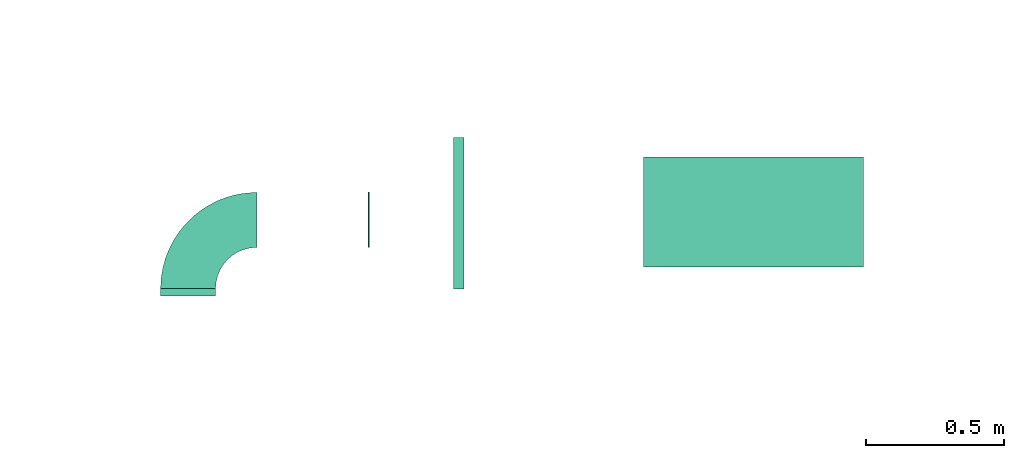
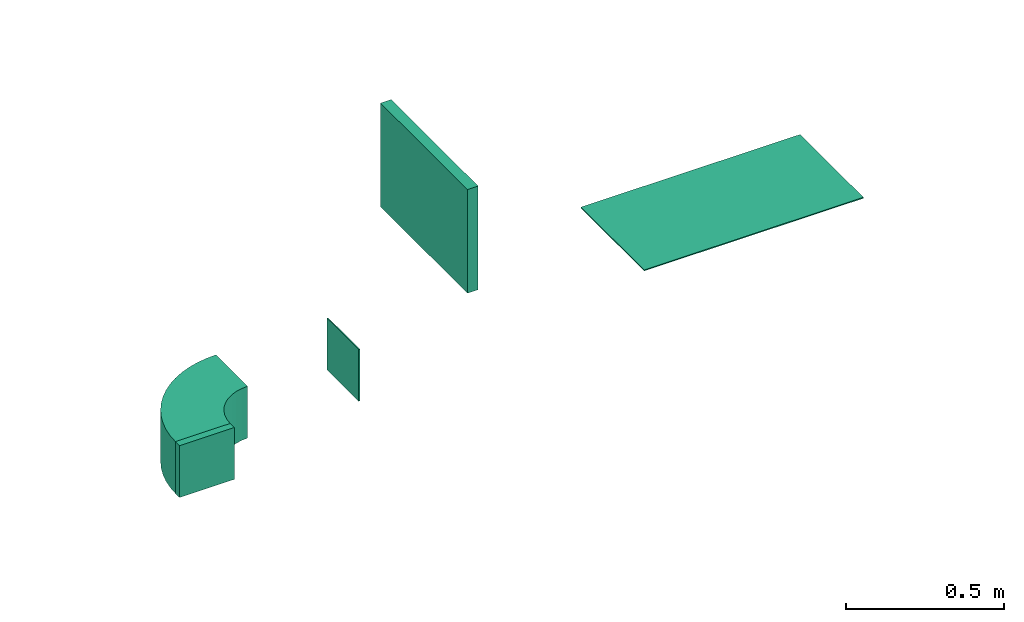
# One storey, part 3 of 7: 2 flow fittings, 2 flow terminals, 1 flow segment.
"""IFC2X3 building model written with IfcOpenShell, lengths in millimetres."""

from ifc_helpers import new_model, entity, si_unit, converted_unit, derived_unit, direction, frame, frame_2d, origin, origin_2d_with_axis, place, context, subcontext, project, spatial, polyline, circle_curve, parameter, trimmed, segment, composite_curve, rectangle, outline, extrude, source, transform, mapped, material, type_object, type_shapes, element, save


model = new_model("IFC2X3")

# Units and contexts
model_context = context("Model", 3, precision=0.01, world=origin(), true_north=direction((6.12303176911189e-17, 1.0)))
body_context = subcontext(model_context, "Body", "Model", "MODEL_VIEW")
ifc_project = project(units=[si_unit("LENGTHUNIT", "METRE", prefix="MILLI"), si_unit("AREAUNIT", "SQUARE_METRE"), si_unit("VOLUMEUNIT", "CUBIC_METRE"), converted_unit("PLANEANGLEUNIT", "DEGREE", entity("IfcRatioMeasure", 0.0174532925199433), si_unit("PLANEANGLEUNIT", "RADIAN"), dimensions=[0, 0, 0, 0, 0, 0, 0]), si_unit("MASSUNIT", "GRAM", prefix="KILO"), derived_unit("MASSDENSITYUNIT", [(si_unit("MASSUNIT", "GRAM", prefix="KILO"), 1), (si_unit("LENGTHUNIT", "METRE"), -3)]), derived_unit("MOMENTOFINERTIAUNIT", [(si_unit("LENGTHUNIT", "METRE"), 4)]), si_unit("TIMEUNIT", "SECOND"), si_unit("FREQUENCYUNIT", "HERTZ"), si_unit("THERMODYNAMICTEMPERATUREUNIT", "DEGREE_CELSIUS"), derived_unit("THERMALTRANSMITTANCEUNIT", [(si_unit("MASSUNIT", "GRAM", prefix="KILO"), 1), (si_unit("THERMODYNAMICTEMPERATUREUNIT", "KELVIN"), -1), (si_unit("TIMEUNIT", "SECOND"), -3)]), derived_unit("VOLUMETRICFLOWRATEUNIT", [(si_unit("LENGTHUNIT", "METRE"), 3), (si_unit("TIMEUNIT", "SECOND"), -1)]), derived_unit("MASSFLOWRATEUNIT", [(si_unit("MASSUNIT", "GRAM", prefix="KILO"), 1), (si_unit("TIMEUNIT", "SECOND"), -1)]), derived_unit("ROTATIONALFREQUENCYUNIT", [(si_unit("TIMEUNIT", "SECOND"), -1)]), si_unit("ELECTRICCURRENTUNIT", "AMPERE"), si_unit("ELECTRICVOLTAGEUNIT", "VOLT"), si_unit("POWERUNIT", "WATT"), si_unit("FORCEUNIT", "NEWTON", prefix="KILO"), si_unit("ILLUMINANCEUNIT", "LUX"), si_unit("LUMINOUSFLUXUNIT", "LUMEN"), si_unit("LUMINOUSINTENSITYUNIT", "CANDELA"), derived_unit("USERDEFINED", [(si_unit("MASSUNIT", "GRAM", prefix="KILO"), -1), (si_unit("LENGTHUNIT", "METRE"), -2), (si_unit("TIMEUNIT", "SECOND"), 3), (si_unit("LUMINOUSFLUXUNIT", "LUMEN"), 1)]), derived_unit("LINEARVELOCITYUNIT", [(si_unit("LENGTHUNIT", "METRE"), 1), (si_unit("TIMEUNIT", "SECOND"), -1)]), si_unit("PRESSUREUNIT", "PASCAL"), derived_unit("USERDEFINED", [(si_unit("LENGTHUNIT", "METRE"), -2), (si_unit("MASSUNIT", "GRAM", prefix="KILO"), 1), (si_unit("TIMEUNIT", "SECOND"), -2)]), derived_unit("LINEARFORCEUNIT", [(si_unit("MASSUNIT", "GRAM", prefix="KILO"), 1), (si_unit("LENGTHUNIT", "METRE"), 1), (si_unit("TIMEUNIT", "SECOND"), -2), (si_unit("LENGTHUNIT", "METRE"), -1)]), derived_unit("PLANARFORCEUNIT", [(si_unit("MASSUNIT", "GRAM", prefix="KILO"), 1), (si_unit("LENGTHUNIT", "METRE"), 1), (si_unit("TIMEUNIT", "SECOND"), -2), (si_unit("LENGTHUNIT", "METRE"), -2)])], contexts=[model_context])

# Site, building, storey
site_placement = place(None, frame((0.0, -0.00077364408347762, 0.0)))
site = spatial("IfcSite", under=ifc_project, at=site_placement, CompositionType="ELEMENT")
building_placement = place(site_placement, origin())
building = spatial("IfcBuilding", under=site, at=building_placement, CompositionType="ELEMENT")
storey_placement = place(building_placement, frame((0.0, 0.0, 15900.0)))
storey = spatial("IfcBuildingStorey", under=building, at=storey_placement, CompositionType="ELEMENT", Elevation=15900.0)

# Flow segment
duct_segment_type = type_object("IfcDuctSegmentType", PredefinedType="NOTDEFINED")
flow_segment_placement = place(storey_placement, frame((11209.734013402, 14469.5640511154, 3000.0)))
element("IfcFlowSegment", 1, at=flow_segment_placement, inside=storey, type_object=duct_segment_type, context=body_context, shape_type="SweptSolid", body=[
    extrude(rectangle(XDim=38.7531418678463, YDim=550.000000000001, at=frame_2d((-1.08357767203415e-12, 0.0), x_axis=(1.0, 0.0))), frame((19.3765709339242, 275.0, 0.0)), (0.0, 0.0, 1.0), 400.0),
])

# Flow terminal
ifc_material_1 = material()
air_terminal_type_1 = type_object("IfcAirTerminalType", PredefinedType="NOTDEFINED", material=ifc_material_1)
shared_shape_1 = source(origin(), body_context, "Body", "SweptSolid", [
    extrude(rectangle(XDim=4.0, YDim=799.999999999999, at=origin_2d_with_axis()), frame((0.0, -2.0, -200.0), z_axis=(0.0, 0.0, 1.0), x_axis=(0.0, 1.0, 0.0)), (0.0, 0.0, 1.0), 400.000000000005),
])
type_shapes(air_terminal_type_1, [shared_shape_1])
flow_terminal_1_placement = place(storey_placement, frame((12300.1283257901, 14749.0835453812, 2800.0), z_axis=(0.0, 1.0, 0.0), x_axis=(-1.0, 0.0, 0.0)))
element("IfcFlowTerminal", 2, at=flow_terminal_1_placement, inside=storey, type_object=air_terminal_type_1, material=ifc_material_1, context=body_context, shape_type="MappedRepresentation", body=[
    mapped(shared_shape_1, transform((0.0, 0.0, 0.0), scale=1.0)),
])

# Flow fitting
ifc_material_2 = material()
duct_fitting_type_1 = type_object("IfcDuctFittingType", PredefinedType="NOTDEFINED", material=ifc_material_2)
shared_shape_2 = source(origin(), body_context, "Body", "SweptSolid", [
    extrude(outline(composite_curve([segment(polyline([(-225.0, -125.0), (-25.0, -125.0)]), True, "CONTINUOUS"), segment(trimmed(circle_curve(frame_2d((125.0, -125.0), x_axis=(0.0, 1.0)), 150.0), [parameter(0.0)], [parameter(90.0000000000001)], True, "PARAMETER"), False, "CONTINUOUS"), segment(polyline([(125.0, 25.0), (125.0, 225.0)]), True, "CONTINUOUS"), segment(trimmed(circle_curve(frame_2d((125.0, -125.0), x_axis=(0.0, 1.0)), 350.0), [parameter(0.0)], [parameter(90.0000000000001)], True, "PARAMETER"), True, "CONTINUOUS")], self_intersect=False)), frame((-125.0, 125.0, -100.0), z_axis=(0.0, 0.0, 1.0), x_axis=(-1.0, 0.0, 0.0)), (0.0, 0.0, 1.0), 200.0),
])
type_shapes(duct_fitting_type_1, [shared_shape_2])
flow_fitting_1_placement = place(storey_placement, frame((10244.7174683872, 14720.8402530396, 2700.0), z_axis=(0.0, 0.0, 1.0), x_axis=(-1.0, 0.0, 0.0)))
element("IfcFlowFitting", 3, at=flow_fitting_1_placement, inside=storey, type_object=duct_fitting_type_1, material=ifc_material_2, context=body_context, shape_type="MappedRepresentation", body=[
    mapped(shared_shape_2, transform((0.0, 0.0, 0.0), scale=1.0)),
])

# Flow terminal
air_terminal_type_2 = type_object("IfcAirTerminalType", PredefinedType="NOTDEFINED", material=ifc_material_1)
shared_shape_3 = source(origin(), body_context, "Body", "SweptSolid", [
    extrude(rectangle(XDim=4.0, YDim=199.999999999999, at=origin_2d_with_axis()), frame((0.0, -2.0, -100.0), z_axis=(0.0, 0.0, 1.0), x_axis=(0.0, 1.0, 0.0)), (0.0, 0.0, 1.0), 200.000000000005),
])
type_shapes(air_terminal_type_2, [shared_shape_3])
flow_terminal_2_placement = place(storey_placement, frame((10899.8744854646, 14720.823821278, 2700.0), z_axis=(0.0, 0.0, 1.0), x_axis=(0.0, 1.0, 0.0)))
element("IfcFlowTerminal", 4, at=flow_terminal_2_placement, inside=storey, type_object=air_terminal_type_2, material=ifc_material_1, context=body_context, shape_type="MappedRepresentation", body=[
    mapped(shared_shape_3, transform((0.0, 0.0, 0.0), scale=1.0)),
])

# Flow fitting
duct_fitting_type_2 = type_object("IfcDuctFittingType", PredefinedType="NOTDEFINED", material=ifc_material_2)
shared_shape_4 = source(origin(), body_context, "Body", "SweptSolid", [
    extrude(rectangle(XDim=200.0, YDim=26.096, at=frame_2d((-1.4210854715202e-14, 0.0), x_axis=(1.0, 0.0))), frame((6.95199999999999, 0.0, -100.0), z_axis=(0.0, 0.0, 1.0), x_axis=(0.0, -1.0, 0.0)), (0.0, 0.0, 1.0), 200.0),
])
type_shapes(duct_fitting_type_2, [shared_shape_4])
flow_fitting_2_placement = place(storey_placement, frame((10244.7174683872, 14450.8402530396, 2700.0), z_axis=(1.0, 0.0, 0.0), x_axis=(0.0, 1.0, 0.0)))
element("IfcFlowFitting", 5, at=flow_fitting_2_placement, inside=storey, type_object=duct_fitting_type_2, material=ifc_material_2, context=body_context, shape_type="MappedRepresentation", body=[
    mapped(shared_shape_4, transform((0.0, 0.0, 0.0), scale=1.0)),
])

save(model, "model.ifc")
